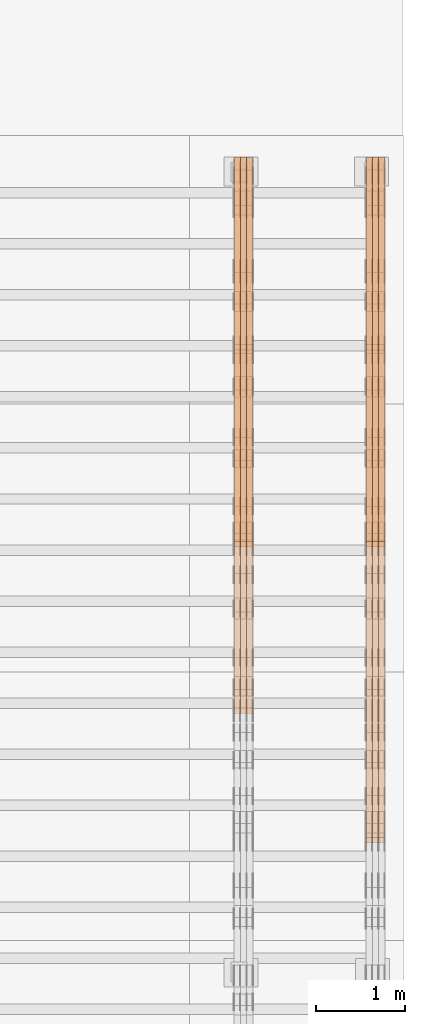
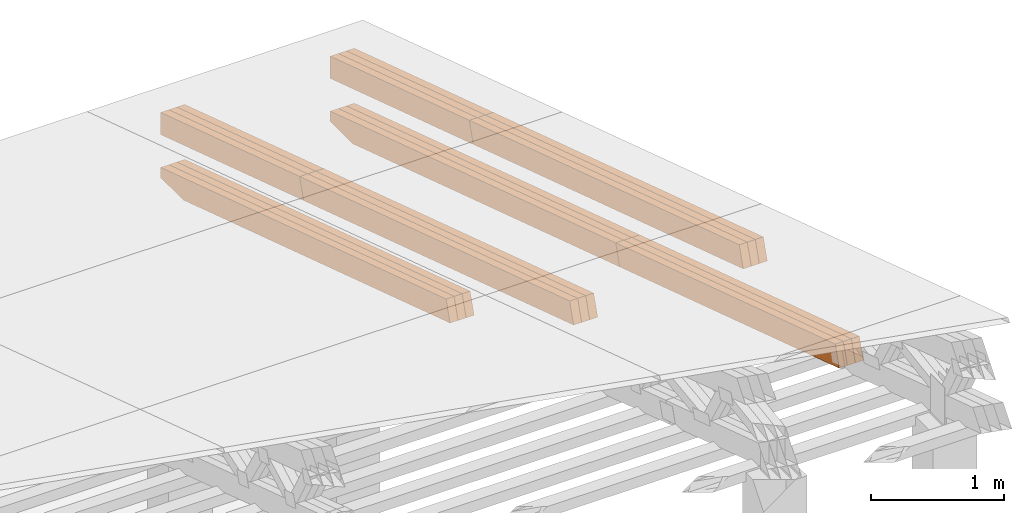
# One storey, part 32 of 385: 21 proxies.
"""IFC2X3 building model written with IfcOpenShell, lengths in millimetres."""

from ifc_helpers import new_model, entity, si_unit, converted_unit, derived_unit, direction, frame, origin, place, context, subcontext, project, spatial, polyline, outline, extrude, source, transform, mapped, material, type_object, type_shapes, element, save


model = new_model("IFC2X3")

# Units and contexts
model_context = context("Model", 3, precision=0.01, world=origin(), true_north=direction((6.12303176911189e-17, 1.0)))
body_context = subcontext(model_context, "Body", "Model", "MODEL_VIEW")
ifc_project = project(units=[si_unit("LENGTHUNIT", "METRE", prefix="MILLI"), si_unit("AREAUNIT", "SQUARE_METRE"), si_unit("VOLUMEUNIT", "CUBIC_METRE"), converted_unit("PLANEANGLEUNIT", "DEGREE", entity("IfcRatioMeasure", 0.0174532925199433), si_unit("PLANEANGLEUNIT", "RADIAN"), dimensions=[0, 0, 0, 0, 0, 0, 0]), si_unit("MASSUNIT", "GRAM", prefix="KILO"), derived_unit("MASSDENSITYUNIT", [(si_unit("MASSUNIT", "GRAM", prefix="KILO"), 1), (si_unit("LENGTHUNIT", "METRE"), -3)]), si_unit("TIMEUNIT", "SECOND"), si_unit("FREQUENCYUNIT", "HERTZ"), si_unit("THERMODYNAMICTEMPERATUREUNIT", "DEGREE_CELSIUS"), derived_unit("THERMALTRANSMITTANCEUNIT", [(si_unit("MASSUNIT", "GRAM", prefix="KILO"), 1), (si_unit("THERMODYNAMICTEMPERATUREUNIT", "KELVIN"), -1), (si_unit("TIMEUNIT", "SECOND"), -3)]), derived_unit("VOLUMETRICFLOWRATEUNIT", [(si_unit("LENGTHUNIT", "METRE"), 3), (si_unit("TIMEUNIT", "SECOND"), -1)]), si_unit("ELECTRICCURRENTUNIT", "AMPERE"), si_unit("ELECTRICVOLTAGEUNIT", "VOLT"), si_unit("POWERUNIT", "WATT"), si_unit("FORCEUNIT", "NEWTON", prefix="KILO"), si_unit("ILLUMINANCEUNIT", "LUX"), si_unit("LUMINOUSFLUXUNIT", "LUMEN"), si_unit("LUMINOUSINTENSITYUNIT", "CANDELA"), derived_unit("USERDEFINED", [(si_unit("MASSUNIT", "GRAM", prefix="KILO"), -1), (si_unit("LENGTHUNIT", "METRE"), -2), (si_unit("TIMEUNIT", "SECOND"), 3), (si_unit("LUMINOUSFLUXUNIT", "LUMEN"), 1)]), derived_unit("LINEARVELOCITYUNIT", [(si_unit("LENGTHUNIT", "METRE"), 1), (si_unit("TIMEUNIT", "SECOND"), -1)]), si_unit("PRESSUREUNIT", "PASCAL"), derived_unit("USERDEFINED", [(si_unit("LENGTHUNIT", "METRE"), -2), (si_unit("MASSUNIT", "GRAM", prefix="KILO"), 1), (si_unit("TIMEUNIT", "SECOND"), -2)])], contexts=[model_context])

# Site, building, storey
site_placement = place(None, origin())
site = spatial("IfcSite", under=ifc_project, at=site_placement, CompositionType="ELEMENT")
building_placement = place(site_placement, origin())
building = spatial("IfcBuilding", under=site, at=building_placement, CompositionType="ELEMENT")
storey_placement = place(building_placement, origin())
storey = spatial("IfcBuildingStorey", under=building, at=storey_placement, Name="Default", CompositionType="ELEMENT", Elevation=0.0)

# Proxies
ifc_material_1 = material(Name="IfcSurfaceStyle #593533")
building_element_proxy_type_1 = type_object("IfcBuildingElementProxyType", Name="T2-T2 593531", PredefinedType="NOTDEFINED", material=ifc_material_1)
shared_shape_1 = source(origin(), body_context, "Body", "SweptSolid", [
    extrude(outline(polyline([(-2137.04373183812, -97.5000250291418), (2137.04394104036, -97.5000250291418), (2137.04396402965, 97.5000250291418), (-2137.04417323189, 97.5000250291418), (-2137.04373183812, -97.5000250291418)])), frame((2137.04396402965, 97.5001541485632, 0.0), z_axis=(0.0, 0.0, 1.0), x_axis=(-1.0, 0.0, 0.0)), (0.0, 0.0, 1.0), 69.9999999999997),
])
type_shapes(building_element_proxy_type_1, [shared_shape_1])
proxy_1_placement = place(building_placement, frame((49860.0, 24344.7841397874, 1095.2368156767), z_axis=(-1.0, 0.0, 0.0), x_axis=(0.0, -0.951056516295154, 0.309016994374948)))
element("IfcBuildingElementProxy", 1, at=proxy_1_placement, inside=storey, type_object=building_element_proxy_type_1, material=ifc_material_1, Name="T2-T2", context=body_context, shape_type="MappedRepresentation", body=[
    mapped(shared_shape_1, transform((0.0, 0.0, 0.0), scale=1.0)),
])
ifc_material_2 = material(Name="IfcSurfaceStyle #593476")
building_element_proxy_type_2 = type_object("IfcBuildingElementProxyType", Name="T2-T2 593474", PredefinedType="NOTDEFINED", material=ifc_material_2)
shared_shape_2 = source(origin(), body_context, "Body", "SweptSolid", [
    extrude(outline(polyline([(-2137.04373183812, -97.5000250291418), (2137.04394104036, -97.5000250291418), (2137.04396402965, 97.5000250291418), (-2137.04417323189, 97.5000250291418), (-2137.04373183812, -97.5000250291418)])), frame((2137.04396402965, 97.5001541485632, 0.0), z_axis=(0.0, 0.0, 1.0), x_axis=(-1.0, 0.0, 0.0)), (0.0, 0.0, 1.0), 69.9999999999997),
])
type_shapes(building_element_proxy_type_2, [shared_shape_2])
proxy_2_placement = place(building_placement, frame((49790.0, 24344.7841397874, 1095.2368156767), z_axis=(-1.0, 0.0, 0.0), x_axis=(0.0, -0.951056516295154, 0.309016994374948)))
element("IfcBuildingElementProxy", 2, at=proxy_2_placement, inside=storey, type_object=building_element_proxy_type_2, material=ifc_material_2, Name="T2-T2", context=body_context, shape_type="MappedRepresentation", body=[
    mapped(shared_shape_2, transform((0.0, 0.0, 0.0), scale=1.0)),
])
ifc_material_3 = material(Name="IfcSurfaceStyle #593419")
building_element_proxy_type_3 = type_object("IfcBuildingElementProxyType", Name="T2-T2 593417", PredefinedType="NOTDEFINED", material=ifc_material_3)
shared_shape_3 = source(origin(), body_context, "Body", "SweptSolid", [
    extrude(outline(polyline([(-2137.04373183812, -97.5000250291418), (2137.04394104036, -97.5000250291418), (2137.04396402965, 97.5000250291418), (-2137.04417323189, 97.5000250291418), (-2137.04373183812, -97.5000250291418)])), frame((2137.04396402965, 97.5001541485632, 0.0), z_axis=(0.0, 0.0, 1.0), x_axis=(-1.0, 0.0, 0.0)), (0.0, 0.0, 1.0), 69.9999999999997),
])
type_shapes(building_element_proxy_type_3, [shared_shape_3])
proxy_3_placement = place(building_placement, frame((49720.0, 24344.7841397874, 1095.2368156767), z_axis=(-1.0, 0.0, 0.0), x_axis=(0.0, -0.951056516295154, 0.309016994374948)))
element("IfcBuildingElementProxy", 3, at=proxy_3_placement, inside=storey, type_object=building_element_proxy_type_3, material=ifc_material_3, Name="T2-T2", context=body_context, shape_type="MappedRepresentation", body=[
    mapped(shared_shape_3, transform((0.0, 0.0, 0.0), scale=1.0)),
])
ifc_material_4 = material(Name="IfcSurfaceStyle #593362")
building_element_proxy_type_4 = type_object("IfcBuildingElementProxyType", Name="T2-T3 593360", PredefinedType="NOTDEFINED", material=ifc_material_4)
shared_shape_4 = source(origin(), body_context, "Body", "SweptSolid", [
    extrude(outline(polyline([(-1117.22419189679, -97.5000115568039), (1085.54451125458, -97.5000115568039), (1148.90384954971, 97.5000115568039), (-1117.2241689075, 97.5000115568039), (-1117.22419189679, -97.5000115568039)])), frame((1148.90385201956, 97.5000191595882, 0.0), z_axis=(0.0, 0.0, 1.0), x_axis=(-1.0, 0.0, 0.0)), (0.0, 0.0, 1.0), 69.9999999999999),
])
type_shapes(building_element_proxy_type_4, [shared_shape_4])
proxy_4_placement = place(building_placement, frame((49860.0, 26500.0, 394.964866273674), z_axis=(-1.0, 0.0, 0.0), x_axis=(0.0, -0.951056516295154, 0.309016994374948)))
element("IfcBuildingElementProxy", 4, at=proxy_4_placement, inside=storey, type_object=building_element_proxy_type_4, material=ifc_material_4, Name="T2-T3", context=body_context, shape_type="MappedRepresentation", body=[
    mapped(shared_shape_4, transform((0.0, 0.0, 0.0), scale=1.0)),
])
ifc_material_5 = material(Name="IfcSurfaceStyle #593305")
building_element_proxy_type_5 = type_object("IfcBuildingElementProxyType", Name="T2-T3 593303", PredefinedType="NOTDEFINED", material=ifc_material_5)
shared_shape_5 = source(origin(), body_context, "Body", "SweptSolid", [
    extrude(outline(polyline([(-1117.22419189679, -97.5000115568039), (1085.54451125458, -97.5000115568039), (1148.90384954971, 97.5000115568039), (-1117.2241689075, 97.5000115568039), (-1117.22419189679, -97.5000115568039)])), frame((1148.90385201956, 97.5000191595882, 0.0), z_axis=(0.0, 0.0, 1.0), x_axis=(-1.0, 0.0, 0.0)), (0.0, 0.0, 1.0), 69.9999999999999),
])
type_shapes(building_element_proxy_type_5, [shared_shape_5])
proxy_5_placement = place(building_placement, frame((49790.0, 26500.0, 394.964866273674), z_axis=(-1.0, 0.0, 0.0), x_axis=(0.0, -0.951056516295154, 0.309016994374948)))
element("IfcBuildingElementProxy", 5, at=proxy_5_placement, inside=storey, type_object=building_element_proxy_type_5, material=ifc_material_5, Name="T2-T3", context=body_context, shape_type="MappedRepresentation", body=[
    mapped(shared_shape_5, transform((0.0, 0.0, 0.0), scale=1.0)),
])
ifc_material_6 = material(Name="IfcSurfaceStyle #593248")
building_element_proxy_type_6 = type_object("IfcBuildingElementProxyType", Name="T2-T3 593246", PredefinedType="NOTDEFINED", material=ifc_material_6)
shared_shape_6 = source(origin(), body_context, "Body", "SweptSolid", [
    extrude(outline(polyline([(-1117.22419189679, -97.5000115568039), (1085.54451125458, -97.5000115568039), (1148.90384954971, 97.5000115568039), (-1117.2241689075, 97.5000115568039), (-1117.22419189679, -97.5000115568039)])), frame((1148.90385201956, 97.5000191595882, 0.0), z_axis=(0.0, 0.0, 1.0), x_axis=(-1.0, 0.0, 0.0)), (0.0, 0.0, 1.0), 69.9999999999999),
])
type_shapes(building_element_proxy_type_6, [shared_shape_6])
proxy_6_placement = place(building_placement, frame((49720.0, 26500.0, 394.964866273674), z_axis=(-1.0, 0.0, 0.0), x_axis=(0.0, -0.951056516295154, 0.309016994374948)))
element("IfcBuildingElementProxy", 6, at=proxy_6_placement, inside=storey, type_object=building_element_proxy_type_6, material=ifc_material_6, Name="T2-T3", context=body_context, shape_type="MappedRepresentation", body=[
    mapped(shared_shape_6, transform((0.0, 0.0, 0.0), scale=1.0)),
])
ifc_material_7 = material(Name="IfcSurfaceStyle #592138")
building_element_proxy_type_7 = type_object("IfcBuildingElementProxyType", Name="T2-B2 592136", PredefinedType="NOTDEFINED", material=ifc_material_7)
shared_shape_7 = source(origin(), body_context, "Body", "SweptSolid", [
    extrude(outline(polyline([(-1738.61933402934, -97.4999466901035), (1738.6190788485, -97.4999466901035), (1738.6191018378, 97.4999466901035), (-1738.61884665697, 97.4999466901035), (-1738.61933402934, -97.4999466901035)])), frame((1738.6191018378, 97.4999528847471, 0.0), z_axis=(0.0, 0.0, 1.0), x_axis=(-1.0, 0.0, 0.0)), (0.0, 0.0, 1.0), 69.9999999999998),
])
type_shapes(building_element_proxy_type_7, [shared_shape_7])
proxy_7_placement = place(building_placement, frame((49860.0, 22140.4521465233, 1306.03026754604), z_axis=(-1.0, 0.0, 0.0), x_axis=(0.0, -0.951056516295124, 0.309016994375039)))
element("IfcBuildingElementProxy", 7, at=proxy_7_placement, inside=storey, type_object=building_element_proxy_type_7, material=ifc_material_7, Name="T2-B2", context=body_context, shape_type="MappedRepresentation", body=[
    mapped(shared_shape_7, transform((0.0, 0.0, 0.0), scale=1.0)),
])
ifc_material_8 = material(Name="IfcSurfaceStyle #592081")
building_element_proxy_type_8 = type_object("IfcBuildingElementProxyType", Name="T2-B2 592079", PredefinedType="NOTDEFINED", material=ifc_material_8)
shared_shape_8 = source(origin(), body_context, "Body", "SweptSolid", [
    extrude(outline(polyline([(-1738.61933402934, -97.4999466901035), (1738.6190788485, -97.4999466901035), (1738.6191018378, 97.4999466901035), (-1738.61884665697, 97.4999466901035), (-1738.61933402934, -97.4999466901035)])), frame((1738.6191018378, 97.4999528847471, 0.0), z_axis=(0.0, 0.0, 1.0), x_axis=(-1.0, 0.0, 0.0)), (0.0, 0.0, 1.0), 69.9999999999998),
])
type_shapes(building_element_proxy_type_8, [shared_shape_8])
proxy_8_placement = place(building_placement, frame((49790.0, 22140.4521465233, 1306.03026754604), z_axis=(-1.0, 0.0, 0.0), x_axis=(0.0, -0.951056516295124, 0.309016994375039)))
element("IfcBuildingElementProxy", 8, at=proxy_8_placement, inside=storey, type_object=building_element_proxy_type_8, material=ifc_material_8, Name="T2-B2", context=body_context, shape_type="MappedRepresentation", body=[
    mapped(shared_shape_8, transform((0.0, 0.0, 0.0), scale=1.0)),
])
ifc_material_9 = material(Name="IfcSurfaceStyle #592024")
building_element_proxy_type_9 = type_object("IfcBuildingElementProxyType", Name="T2-B2 592022", PredefinedType="NOTDEFINED", material=ifc_material_9)
shared_shape_9 = source(origin(), body_context, "Body", "SweptSolid", [
    extrude(outline(polyline([(-1738.61933402934, -97.4999466901035), (1738.6190788485, -97.4999466901035), (1738.6191018378, 97.4999466901035), (-1738.61884665697, 97.4999466901035), (-1738.61933402934, -97.4999466901035)])), frame((1738.6191018378, 97.4999528847471, 0.0), z_axis=(0.0, 0.0, 1.0), x_axis=(-1.0, 0.0, 0.0)), (0.0, 0.0, 1.0), 69.9999999999998),
])
type_shapes(building_element_proxy_type_9, [shared_shape_9])
proxy_9_placement = place(building_placement, frame((49720.0, 22140.4521465233, 1306.03026754604), z_axis=(-1.0, 0.0, 0.0), x_axis=(0.0, -0.951056516295124, 0.309016994375039)))
element("IfcBuildingElementProxy", 9, at=proxy_9_placement, inside=storey, type_object=building_element_proxy_type_9, material=ifc_material_9, Name="T2-B2", context=body_context, shape_type="MappedRepresentation", body=[
    mapped(shared_shape_9, transform((0.0, 0.0, 0.0), scale=1.0)),
])
ifc_material_10 = material(Name="IfcSurfaceStyle #591967")
building_element_proxy_type_10 = type_object("IfcBuildingElementProxyType", Name="T2-B1 591965", PredefinedType="NOTDEFINED", material=ifc_material_10)
shared_shape_10 = source(origin(), body_context, "Body", "SweptSolid", [
    extrude(outline(polyline([(-2659.34106034305, -95.9868650736445), (1861.19950396595, -95.9868650736445), (1890.42090463564, -6.05260867570997), (1567.0616890952, 99.0131694114995), (-2659.34103735375, 99.0131694114995), (-2659.34106034305, -95.9868650736445)])), frame((1890.42090463564, 99.013169411504, 0.0), z_axis=(0.0, 0.0, 1.0), x_axis=(-1.0, 0.0, 0.0)), (0.0, 0.0, 1.0), 69.9999999999997),
])
type_shapes(building_element_proxy_type_10, [shared_shape_10])
proxy_10_placement = place(building_placement, frame((49860.0, 26467.5328890438, -99.9234928894624), z_axis=(-1.0, 0.0, 0.0), x_axis=(0.0, -0.951056516295124, 0.309016994375039)))
element("IfcBuildingElementProxy", 10, at=proxy_10_placement, inside=storey, type_object=building_element_proxy_type_10, material=ifc_material_10, Name="T2-B1", context=body_context, shape_type="MappedRepresentation", body=[
    mapped(shared_shape_10, transform((0.0, 0.0, 0.0), scale=1.0)),
])
ifc_material_11 = material(Name="IfcSurfaceStyle #591901")
building_element_proxy_type_11 = type_object("IfcBuildingElementProxyType", Name="T2-B1 591899", PredefinedType="NOTDEFINED", material=ifc_material_11)
shared_shape_11 = source(origin(), body_context, "Body", "SweptSolid", [
    extrude(outline(polyline([(-2659.34106034305, -95.9868650736445), (1861.19950396595, -95.9868650736445), (1890.42090463564, -6.05260867570997), (1567.0616890952, 99.0131694114995), (-2659.34103735375, 99.0131694114995), (-2659.34106034305, -95.9868650736445)])), frame((1890.42090463564, 99.013169411504, 0.0), z_axis=(0.0, 0.0, 1.0), x_axis=(-1.0, 0.0, 0.0)), (0.0, 0.0, 1.0), 69.9999999999997),
])
type_shapes(building_element_proxy_type_11, [shared_shape_11])
proxy_11_placement = place(building_placement, frame((49790.0, 26467.5328890438, -99.9234928894624), z_axis=(-1.0, 0.0, 0.0), x_axis=(0.0, -0.951056516295124, 0.309016994375039)))
element("IfcBuildingElementProxy", 11, at=proxy_11_placement, inside=storey, type_object=building_element_proxy_type_11, material=ifc_material_11, Name="T2-B1", context=body_context, shape_type="MappedRepresentation", body=[
    mapped(shared_shape_11, transform((0.0, 0.0, 0.0), scale=1.0)),
])
ifc_material_12 = material(Name="IfcSurfaceStyle #591835")
building_element_proxy_type_12 = type_object("IfcBuildingElementProxyType", Name="T2-B1 591833", PredefinedType="NOTDEFINED", material=ifc_material_12)
shared_shape_12 = source(origin(), body_context, "Body", "SweptSolid", [
    extrude(outline(polyline([(-2659.34106034305, -95.9868650736445), (1861.19950396595, -95.9868650736445), (1890.42090463564, -6.05260867570997), (1567.0616890952, 99.0131694114995), (-2659.34103735375, 99.0131694114995), (-2659.34106034305, -95.9868650736445)])), frame((1890.42090463564, 99.013169411504, 0.0), z_axis=(0.0, 0.0, 1.0), x_axis=(-1.0, 0.0, 0.0)), (0.0, 0.0, 1.0), 69.9999999999997),
])
type_shapes(building_element_proxy_type_12, [shared_shape_12])
proxy_12_placement = place(building_placement, frame((49720.0, 26467.5328890438, -99.9234928894624), z_axis=(-1.0, 0.0, 0.0), x_axis=(0.0, -0.951056516295124, 0.309016994375039)))
element("IfcBuildingElementProxy", 12, at=proxy_12_placement, inside=storey, type_object=building_element_proxy_type_12, material=ifc_material_12, Name="T2-B1", context=body_context, shape_type="MappedRepresentation", body=[
    mapped(shared_shape_12, transform((0.0, 0.0, 0.0), scale=1.0)),
])
ifc_material_13 = material(Name="IfcSurfaceStyle #559101")
building_element_proxy_type_13 = type_object("IfcBuildingElementProxyType", Name="T1-T2 559099", PredefinedType="NOTDEFINED", material=ifc_material_13)
shared_shape_13 = source(origin(), body_context, "Body", "SweptSolid", [
    extrude(outline(polyline([(-2137.04373183812, -97.5000250291418), (2137.04394104036, -97.5000250291418), (2137.04396402965, 97.5000250291418), (-2137.04417323189, 97.5000250291418), (-2137.04373183812, -97.5000250291418)])), frame((2137.04396402965, 97.5001541485632, 0.0), z_axis=(0.0, 0.0, 1.0), x_axis=(-1.0, 0.0, 0.0)), (0.0, 0.0, 1.0), 69.9999999999997),
])
type_shapes(building_element_proxy_type_13, [shared_shape_13])
proxy_13_placement = place(building_placement, frame((48385.0, 24344.7841397874, 1095.2368156767), z_axis=(-1.0, 0.0, 0.0), x_axis=(0.0, -0.951056516295154, 0.309016994374948)))
element("IfcBuildingElementProxy", 13, at=proxy_13_placement, inside=storey, type_object=building_element_proxy_type_13, material=ifc_material_13, Name="T1-T2", context=body_context, shape_type="MappedRepresentation", body=[
    mapped(shared_shape_13, transform((0.0, 0.0, 0.0), scale=1.0)),
])
ifc_material_14 = material(Name="IfcSurfaceStyle #559044")
building_element_proxy_type_14 = type_object("IfcBuildingElementProxyType", Name="T1-T2 559042", PredefinedType="NOTDEFINED", material=ifc_material_14)
shared_shape_14 = source(origin(), body_context, "Body", "SweptSolid", [
    extrude(outline(polyline([(-2137.04373183812, -97.5000250291418), (2137.04394104036, -97.5000250291418), (2137.04396402965, 97.5000250291418), (-2137.04417323189, 97.5000250291418), (-2137.04373183812, -97.5000250291418)])), frame((2137.04396402965, 97.5001541485632, 0.0), z_axis=(0.0, 0.0, 1.0), x_axis=(-1.0, 0.0, 0.0)), (0.0, 0.0, 1.0), 69.9999999999997),
])
type_shapes(building_element_proxy_type_14, [shared_shape_14])
proxy_14_placement = place(building_placement, frame((48315.0, 24344.7841397874, 1095.2368156767), z_axis=(-1.0, 0.0, 0.0), x_axis=(0.0, -0.951056516295154, 0.309016994374948)))
element("IfcBuildingElementProxy", 14, at=proxy_14_placement, inside=storey, type_object=building_element_proxy_type_14, material=ifc_material_14, Name="T1-T2", context=body_context, shape_type="MappedRepresentation", body=[
    mapped(shared_shape_14, transform((0.0, 0.0, 0.0), scale=1.0)),
])
ifc_material_15 = material(Name="IfcSurfaceStyle #558987")
building_element_proxy_type_15 = type_object("IfcBuildingElementProxyType", Name="T1-T2 558985", PredefinedType="NOTDEFINED", material=ifc_material_15)
shared_shape_15 = source(origin(), body_context, "Body", "SweptSolid", [
    extrude(outline(polyline([(-2137.04373183812, -97.5000250291418), (2137.04394104036, -97.5000250291418), (2137.04396402965, 97.5000250291418), (-2137.04417323189, 97.5000250291418), (-2137.04373183812, -97.5000250291418)])), frame((2137.04396402965, 97.5001541485632, 0.0), z_axis=(0.0, 0.0, 1.0), x_axis=(-1.0, 0.0, 0.0)), (0.0, 0.0, 1.0), 69.9999999999997),
])
type_shapes(building_element_proxy_type_15, [shared_shape_15])
proxy_15_placement = place(building_placement, frame((48245.0, 24344.7841397874, 1095.2368156767), z_axis=(-1.0, 0.0, 0.0), x_axis=(0.0, -0.951056516295154, 0.309016994374948)))
element("IfcBuildingElementProxy", 15, at=proxy_15_placement, inside=storey, type_object=building_element_proxy_type_15, material=ifc_material_15, Name="T1-T2", context=body_context, shape_type="MappedRepresentation", body=[
    mapped(shared_shape_15, transform((0.0, 0.0, 0.0), scale=1.0)),
])
ifc_material_16 = material(Name="IfcSurfaceStyle #558930")
building_element_proxy_type_16 = type_object("IfcBuildingElementProxyType", Name="T1-T3 558928", PredefinedType="NOTDEFINED", material=ifc_material_16)
shared_shape_16 = source(origin(), body_context, "Body", "SweptSolid", [
    extrude(outline(polyline([(-1117.22419189679, -97.5000115568039), (1085.54451125458, -97.5000115568039), (1148.90384954971, 97.5000115568039), (-1117.2241689075, 97.5000115568039), (-1117.22419189679, -97.5000115568039)])), frame((1148.90385201956, 97.5000191595882, 0.0), z_axis=(0.0, 0.0, 1.0), x_axis=(-1.0, 0.0, 0.0)), (0.0, 0.0, 1.0), 69.9999999999999),
])
type_shapes(building_element_proxy_type_16, [shared_shape_16])
proxy_16_placement = place(building_placement, frame((48385.0, 26500.0, 394.964866273674), z_axis=(-1.0, 0.0, 0.0), x_axis=(0.0, -0.951056516295154, 0.309016994374948)))
element("IfcBuildingElementProxy", 16, at=proxy_16_placement, inside=storey, type_object=building_element_proxy_type_16, material=ifc_material_16, Name="T1-T3", context=body_context, shape_type="MappedRepresentation", body=[
    mapped(shared_shape_16, transform((0.0, 0.0, 0.0), scale=1.0)),
])
ifc_material_17 = material(Name="IfcSurfaceStyle #558873")
building_element_proxy_type_17 = type_object("IfcBuildingElementProxyType", Name="T1-T3 558871", PredefinedType="NOTDEFINED", material=ifc_material_17)
shared_shape_17 = source(origin(), body_context, "Body", "SweptSolid", [
    extrude(outline(polyline([(-1117.22419189679, -97.5000115568039), (1085.54451125458, -97.5000115568039), (1148.90384954971, 97.5000115568039), (-1117.2241689075, 97.5000115568039), (-1117.22419189679, -97.5000115568039)])), frame((1148.90385201956, 97.5000191595882, 0.0), z_axis=(0.0, 0.0, 1.0), x_axis=(-1.0, 0.0, 0.0)), (0.0, 0.0, 1.0), 69.9999999999999),
])
type_shapes(building_element_proxy_type_17, [shared_shape_17])
proxy_17_placement = place(building_placement, frame((48315.0, 26500.0, 394.964866273674), z_axis=(-1.0, 0.0, 0.0), x_axis=(0.0, -0.951056516295154, 0.309016994374948)))
element("IfcBuildingElementProxy", 17, at=proxy_17_placement, inside=storey, type_object=building_element_proxy_type_17, material=ifc_material_17, Name="T1-T3", context=body_context, shape_type="MappedRepresentation", body=[
    mapped(shared_shape_17, transform((0.0, 0.0, 0.0), scale=1.0)),
])
ifc_material_18 = material(Name="IfcSurfaceStyle #558816")
building_element_proxy_type_18 = type_object("IfcBuildingElementProxyType", Name="T1-T3 558814", PredefinedType="NOTDEFINED", material=ifc_material_18)
shared_shape_18 = source(origin(), body_context, "Body", "SweptSolid", [
    extrude(outline(polyline([(-1117.22419189679, -97.5000115568039), (1085.54451125458, -97.5000115568039), (1148.90384954971, 97.5000115568039), (-1117.2241689075, 97.5000115568039), (-1117.22419189679, -97.5000115568039)])), frame((1148.90385201956, 97.5000191595882, 0.0), z_axis=(0.0, 0.0, 1.0), x_axis=(-1.0, 0.0, 0.0)), (0.0, 0.0, 1.0), 69.9999999999999),
])
type_shapes(building_element_proxy_type_18, [shared_shape_18])
proxy_18_placement = place(building_placement, frame((48245.0, 26500.0, 394.964866273674), z_axis=(-1.0, 0.0, 0.0), x_axis=(0.0, -0.951056516295154, 0.309016994374948)))
element("IfcBuildingElementProxy", 18, at=proxy_18_placement, inside=storey, type_object=building_element_proxy_type_18, material=ifc_material_18, Name="T1-T3", context=body_context, shape_type="MappedRepresentation", body=[
    mapped(shared_shape_18, transform((0.0, 0.0, 0.0), scale=1.0)),
])
ifc_material_19 = material(Name="IfcSurfaceStyle #557535")
building_element_proxy_type_19 = type_object("IfcBuildingElementProxyType", Name="T1-B1 557533", PredefinedType="NOTDEFINED", material=ifc_material_19)
shared_shape_19 = source(origin(), body_context, "Body", "SweptSolid", [
    extrude(outline(polyline([(-2659.34106034305, -95.9868650736445), (1861.19950396595, -95.9868650736445), (1890.42090463564, -6.05260867570997), (1567.0616890952, 99.0131694114995), (-2659.34103735375, 99.0131694114995), (-2659.34106034305, -95.9868650736445)])), frame((1890.42090463564, 99.013169411504, 0.0), z_axis=(0.0, 0.0, 1.0), x_axis=(-1.0, 0.0, 0.0)), (0.0, 0.0, 1.0), 69.9999999999997),
])
type_shapes(building_element_proxy_type_19, [shared_shape_19])
proxy_19_placement = place(building_placement, frame((48385.0, 26467.5328890438, -99.9234928894624), z_axis=(-1.0, 0.0, 0.0), x_axis=(0.0, -0.951056516295124, 0.309016994375039)))
element("IfcBuildingElementProxy", 19, at=proxy_19_placement, inside=storey, type_object=building_element_proxy_type_19, material=ifc_material_19, Name="T1-B1", context=body_context, shape_type="MappedRepresentation", body=[
    mapped(shared_shape_19, transform((0.0, 0.0, 0.0), scale=1.0)),
])
ifc_material_20 = material(Name="IfcSurfaceStyle #557469")
building_element_proxy_type_20 = type_object("IfcBuildingElementProxyType", Name="T1-B1 557467", PredefinedType="NOTDEFINED", material=ifc_material_20)
shared_shape_20 = source(origin(), body_context, "Body", "SweptSolid", [
    extrude(outline(polyline([(-2659.34106034305, -95.9868650736445), (1861.19950396595, -95.9868650736445), (1890.42090463564, -6.05260867570997), (1567.0616890952, 99.0131694114995), (-2659.34103735375, 99.0131694114995), (-2659.34106034305, -95.9868650736445)])), frame((1890.42090463564, 99.013169411504, 0.0), z_axis=(0.0, 0.0, 1.0), x_axis=(-1.0, 0.0, 0.0)), (0.0, 0.0, 1.0), 69.9999999999997),
])
type_shapes(building_element_proxy_type_20, [shared_shape_20])
proxy_20_placement = place(building_placement, frame((48315.0, 26467.5328890438, -99.9234928894624), z_axis=(-1.0, 0.0, 0.0), x_axis=(0.0, -0.951056516295124, 0.309016994375039)))
element("IfcBuildingElementProxy", 20, at=proxy_20_placement, inside=storey, type_object=building_element_proxy_type_20, material=ifc_material_20, Name="T1-B1", context=body_context, shape_type="MappedRepresentation", body=[
    mapped(shared_shape_20, transform((0.0, 0.0, 0.0), scale=1.0)),
])
ifc_material_21 = material(Name="IfcSurfaceStyle #557403")
building_element_proxy_type_21 = type_object("IfcBuildingElementProxyType", Name="T1-B1 557401", PredefinedType="NOTDEFINED", material=ifc_material_21)
shared_shape_21 = source(origin(), body_context, "Body", "SweptSolid", [
    extrude(outline(polyline([(-2659.34106034305, -95.9868650736445), (1861.19950396595, -95.9868650736445), (1890.42090463564, -6.05260867570997), (1567.0616890952, 99.0131694114995), (-2659.34103735375, 99.0131694114995), (-2659.34106034305, -95.9868650736445)])), frame((1890.42090463564, 99.013169411504, 0.0), z_axis=(0.0, 0.0, 1.0), x_axis=(-1.0, 0.0, 0.0)), (0.0, 0.0, 1.0), 69.9999999999997),
])
type_shapes(building_element_proxy_type_21, [shared_shape_21])
proxy_21_placement = place(building_placement, frame((48245.0, 26467.5328890438, -99.9234928894624), z_axis=(-1.0, 0.0, 0.0), x_axis=(0.0, -0.951056516295124, 0.309016994375039)))
element("IfcBuildingElementProxy", 21, at=proxy_21_placement, inside=storey, type_object=building_element_proxy_type_21, material=ifc_material_21, Name="T1-B1", context=body_context, shape_type="MappedRepresentation", body=[
    mapped(shared_shape_21, transform((0.0, 0.0, 0.0), scale=1.0)),
])

save(model, "model.ifc")
